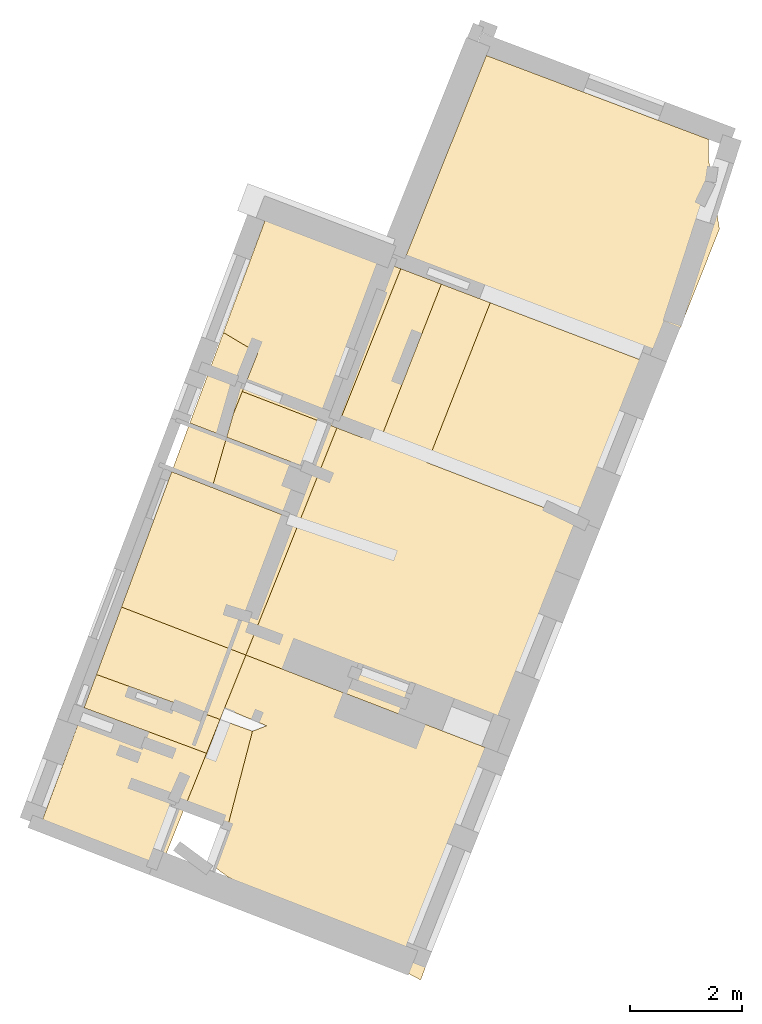
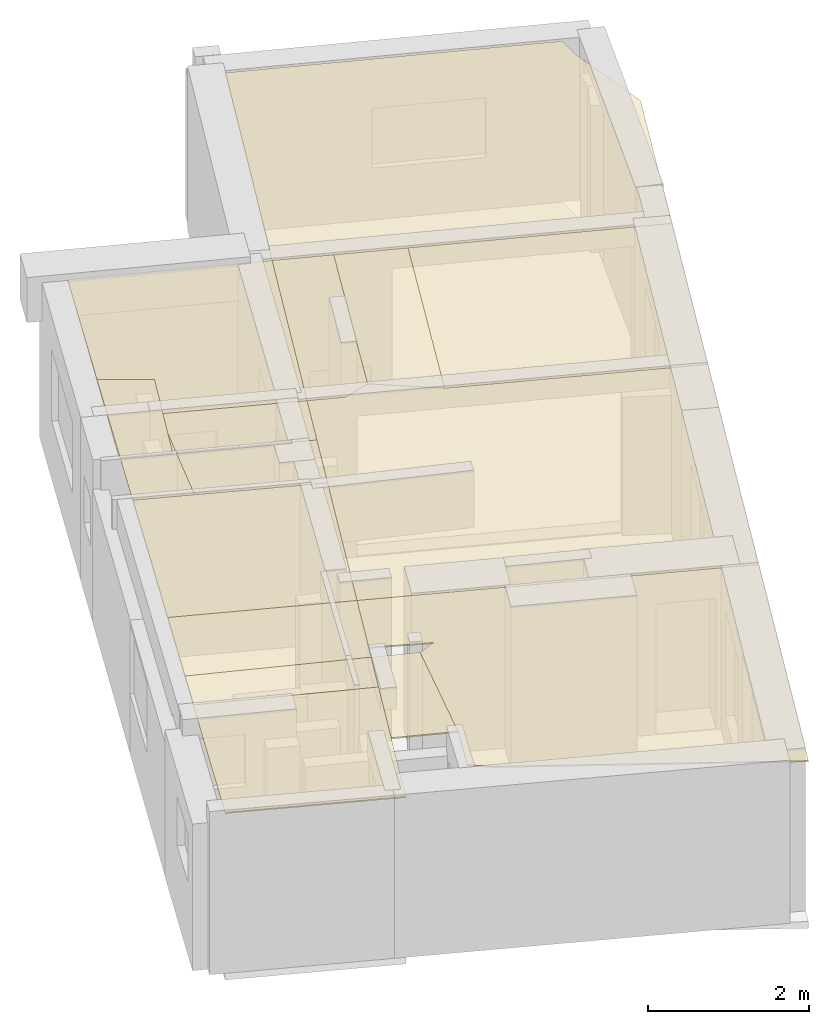
# One storey, part 4 of 5: 16 coverings.
"""IFC2X3 building model written with IfcOpenShell, lengths in metres."""

import ifcopenshell
import ifcopenshell.guid

model = None  # the IFC model being written
_history = None  # IfcOwnerHistory: only IFC2X3 demands one
_inside = {}  # id of a spatial element -> (the spatial element, [elements in it])
_under = {}  # id of a project, library or spatial element -> (it, [spatial elements below it])
_declared = {}  # id of a project -> (the project, [libraries it declares])
_typed = {}  # id of a type object -> (the type object, [elements of that type])
_made_of = {}  # id of a material, layer set ... -> (it, [elements and type objects made of it])


def new_model(schema):
    """Start an empty IFC model of exactly this schema.

    Asked for "IFC4X3", IfcOpenShell would pick the latest addendum, in which some entities
    have other attributes; the version numbers below select the first issue.
    IFC2X3 requires an IfcOwnerHistory on every rooted entity: one is made here for all.
    """
    global model, _history
    if schema == "IFC4X3":
        model = ifcopenshell.file(schema_version=(4, 3, 0, 0))
    else:
        model = ifcopenshell.file(schema=schema)
    _inside.clear()
    _under.clear()
    _declared.clear()
    _typed.clear()
    _made_of.clear()
    _history = None
    if model.schema == "IFC2X3":
        org = make("IfcOrganization", Name="unknown")
        user = make(
            "IfcPersonAndOrganization",
            ThePerson=make("IfcPerson", FamilyName="unknown"),
            TheOrganization=org,
        )
        app = make(
            "IfcApplication",
            ApplicationDeveloper=org,
            Version="unknown",
            ApplicationFullName="unknown",
            ApplicationIdentifier="unknown",
        )
        _history = make(
            "IfcOwnerHistory",
            OwningUser=user,
            OwningApplication=app,
            ChangeAction="ADDED",
            CreationDate=0,
        )
    return model


def make(cls, **values):
    """One entity of the class cls with the attributes given. An attribute that is None is left unset."""
    return model.create_entity(
        cls, **{name: value for name, value in values.items() if value is not None}
    )


def entity(cls, *values):
    """Any entity or typed value of the class cls, its attributes in the order of the schema. None: left unset."""
    e = model.create_entity(cls)
    for i, value in enumerate(values):
        if value is not None:
            e[i] = value
    return e


def rooted(cls, **values):
    """An entity with a GlobalId (a new one), such as an element, a storey or a relation."""
    return make(cls, GlobalId=ifcopenshell.guid.new(), OwnerHistory=_history, **values)


def si_unit(unit_type, name, prefix=None):
    """IfcSIUnit, for example si_unit("LENGTHUNIT", "METRE", prefix="MILLI")."""
    return make("IfcSIUnit", UnitType=unit_type, Prefix=prefix, Name=name)


def converted_unit(unit_type, name, factor, base, dimensions=None, offset=None):
    """IfcConversionBasedUnit, such as the inch: factor (a typed value) times the base unit."""
    return make(
        "IfcConversionBasedUnit"
        if offset is None
        else "IfcConversionBasedUnitWithOffset",
        ConversionOffset=offset,
        Dimensions=None
        if dimensions is None
        else entity("IfcDimensionalExponents", *dimensions),
        UnitType=unit_type,
        Name=name,
        ConversionFactor=make(
            "IfcMeasureWithUnit", ValueComponent=factor, UnitComponent=base
        ),
    )


def derived_unit(unit_type, elements):
    """IfcDerivedUnit: a product of units, each with its exponent."""
    return make(
        "IfcDerivedUnit",
        Elements=[
            make("IfcDerivedUnitElement", Unit=unit, Exponent=power)
            for unit, power in elements
        ],
        UnitType=unit_type,
    )


def assignment(units):
    """IfcUnitAssignment: the units of a project."""
    return None if units is None else make("IfcUnitAssignment", Units=units)


def point(xyz):
    """IfcCartesianPoint."""
    return None if xyz is None else make("IfcCartesianPoint", Coordinates=xyz)


def direction(xyz):
    """IfcDirection."""
    return None if xyz is None else make("IfcDirection", DirectionRatios=xyz)


def frame(location, z_axis=None, x_axis=None):
    """IfcAxis2Placement3D, a coordinate frame: its origin and axes. An axis left out is left unset."""
    return make(
        "IfcAxis2Placement3D",
        Location=point(location),
        Axis=direction(z_axis),
        RefDirection=direction(x_axis),
    )


def origin():
    """The frame at (0, 0, 0) with its axes left unset."""
    return frame((0.0, 0.0, 0.0))


def origin_with_axes():
    """The frame at (0, 0, 0) with the z axis (0, 0, 1) and the x axis (1, 0, 0) written out."""
    return frame((0.0, 0.0, 0.0), z_axis=(0.0, 0.0, 1.0), x_axis=(1.0, 0.0, 0.0))


def place(relative_to, where):
    """IfcLocalPlacement: puts the frame where relative to a parent placement (None: the world)."""
    return make(
        "IfcLocalPlacement", PlacementRelTo=relative_to, RelativePlacement=where
    )


def context(
    kind, dimensions, precision=None, world=None, true_north=None, identifier=None
):
    """IfcGeometricRepresentationContext, for example the 3D "Model" context."""
    return make(
        "IfcGeometricRepresentationContext",
        ContextIdentifier=identifier,
        ContextType=kind,
        CoordinateSpaceDimension=dimensions,
        Precision=precision,
        WorldCoordinateSystem=world,
        TrueNorth=true_north,
    )


def subcontext(parent, identifier, kind, view, scale=None):
    """IfcGeometricRepresentationSubContext, for example "Body" below "Model"."""
    return make(
        "IfcGeometricRepresentationSubContext",
        ContextIdentifier=identifier,
        ContextType=kind,
        ParentContext=parent,
        TargetScale=scale,
        TargetView=view,
    )


def project(units=None, contexts=None):
    """IfcProject with its units and contexts."""
    return rooted(
        "IfcProject",
        Name="project",
        RepresentationContexts=contexts,
        UnitsInContext=assignment(units),
    )


def spatial(cls, under=None, at=None, **own):
    """A site, building, storey or space (cls), placed at a placement, below another one or the project."""
    s = rooted(cls, ObjectPlacement=at, **own)
    if under is not None:
        _under.setdefault(under.id(), (under, []))[1].append(s)
    return s


def polyline(points):
    """IfcPolyline through the points."""
    return make("IfcPolyline", Points=[point(p) for p in points])


def outline(outer, holes=None, kind="AREA"):
    """IfcArbitraryClosedProfileDef: a profile drawn as a closed curve; with holes, ...WithVoids."""
    if holes is None:
        return make("IfcArbitraryClosedProfileDef", ProfileType=kind, OuterCurve=outer)
    return make(
        "IfcArbitraryProfileDefWithVoids",
        ProfileType=kind,
        OuterCurve=outer,
        InnerCurves=holes,
    )


def extrude(swept, where, along, depth):
    """IfcExtrudedAreaSolid: the profile swept, set in the frame where, extruded along a direction by depth."""
    return make(
        "IfcExtrudedAreaSolid",
        SweptArea=swept,
        Position=where,
        ExtrudedDirection=direction(along),
        Depth=depth,
    )


def shape(context_of_items, identifier, shape_type, items):
    """IfcShapeRepresentation: the items that make up one representation, for example the "Body"."""
    return make(
        "IfcShapeRepresentation",
        ContextOfItems=context_of_items,
        RepresentationIdentifier=identifier,
        RepresentationType=shape_type,
        Items=items,
    )


def material(Name=None, Category=None):
    """IfcMaterial."""
    return make("IfcMaterial", Name=Name, Category=Category)


def layer(
    of_material, thickness, ventilated=None, Name=None, Category=None, Priority=None
):
    """IfcMaterialLayer: one layer of a wall or slab, of a material (None: an air gap)."""
    return make(
        "IfcMaterialLayer",
        Material=of_material,
        LayerThickness=thickness,
        IsVentilated=ventilated,
        Name=Name,
        Category=Category,
        Priority=Priority,
    )


def layer_set(layers, Name=None):
    """IfcMaterialLayerSet."""
    return make("IfcMaterialLayerSet", MaterialLayers=layers, LayerSetName=Name)


def layer_usage(for_layer_set, set_direction, sense, offset, extent=None):
    """IfcMaterialLayerSetUsage: how a layer set lies in its element."""
    return make(
        "IfcMaterialLayerSetUsage",
        ForLayerSet=for_layer_set,
        LayerSetDirection=set_direction,
        DirectionSense=sense,
        OffsetFromReferenceLine=offset,
        ReferenceExtent=extent,
    )


def made_of(thing, what):
    """Note that an element or type object is made of a material, layer set ...; save() writes the relation."""
    if what is not None:
        _made_of.setdefault(what.id(), (what, []))[1].append(thing)
    return thing


def type_object(cls, material=None, **own):
    """A type object (cls), such as IfcWallType, which elements share."""
    return made_of(rooted(cls, **own), material)


def element(
    cls,
    number,
    at=None,
    inside=None,
    cuts=None,
    type_object=None,
    material=None,
    context=None,
    identifier="Body",
    shape_type=None,
    held_by="IfcProductDefinitionShape",
    body=None,
    shapes=None,
    **own,
):
    """One element of the class cls, such as IfcWall. Its Tag is "e" and its number.

    at: its placement. inside: the storey or other place that contains it. cuts: it is an
    opening in that element (IfcRelVoidsElement). A single representation is given by context,
    identifier, shape_type and body (its items); several are given by shapes. held_by: the class
    of the entity that holds the representations. save() writes the other relations.
    """
    e = rooted(cls, Tag="e%d" % number, ObjectPlacement=at, **own)
    if body is not None:
        shapes = [shape(context, identifier, shape_type, body)]
    if shapes is not None:
        e.Representation = make(held_by, Representations=shapes)
    if inside is not None:
        _inside.setdefault(inside.id(), (inside, []))[1].append(e)
    if cuts is not None:
        rooted(
            "IfcRelVoidsElement", RelatingBuildingElement=cuts, RelatedOpeningElement=e
        )
    if type_object is not None:
        _typed.setdefault(type_object.id(), (type_object, []))[1].append(e)
    return made_of(e, material)


def aggregate(whole, parts):
    """IfcRelAggregates: a whole, such as a stair, and the parts it consists of."""
    return rooted("IfcRelAggregates", RelatingObject=whole, RelatedObjects=parts)


def save(model, path):
    """Write the relations noted so far, then the file.

    IfcRelAggregates (storeys below a building ...), IfcRelContainedInSpatialStructure (elements
    in a storey), IfcRelDefinesByType, IfcRelAssociatesMaterial and IfcRelDeclares: one each for
    every whole, place, type object, material and project.
    """
    for whole, parts in _under.values():
        aggregate(whole, parts)
    for where, things in _inside.values():
        rooted(
            "IfcRelContainedInSpatialStructure",
            RelatedElements=things,
            RelatingStructure=where,
        )
    for kind, things in _typed.values():
        rooted("IfcRelDefinesByType", RelatedObjects=things, RelatingType=kind)
    for what, things in _made_of.values():
        rooted("IfcRelAssociatesMaterial", RelatedObjects=things, RelatingMaterial=what)
    for by, libraries in _declared.values():
        rooted("IfcRelDeclares", RelatingContext=by, RelatedDefinitions=libraries)
    model.write(path)


model = new_model("IFC2X3")

# Units and contexts
model_context = context("Model", 3, precision=1e-05, world=origin(), true_north=direction((0.0, 1.0)))
body_context = subcontext(model_context, "Body", "Model", "MODEL_VIEW")
ifc_project = project(units=[si_unit("LENGTHUNIT", "METRE"), si_unit("AREAUNIT", "SQUARE_METRE"), si_unit("VOLUMEUNIT", "CUBIC_METRE"), converted_unit("PLANEANGLEUNIT", "DEGREE", entity("IfcRatioMeasure", 0.0174532925199433), si_unit("PLANEANGLEUNIT", "RADIAN"), dimensions=[0, 0, 0, 0, 0, 0, 0]), si_unit("MASSUNIT", "GRAM", prefix="KILO"), derived_unit("MASSDENSITYUNIT", [(si_unit("MASSUNIT", "GRAM", prefix="KILO"), 1), (si_unit("LENGTHUNIT", "METRE"), -3)]), derived_unit("MOMENTOFINERTIAUNIT", [(si_unit("LENGTHUNIT", "METRE"), 4)]), si_unit("TIMEUNIT", "SECOND"), si_unit("FREQUENCYUNIT", "HERTZ"), si_unit("THERMODYNAMICTEMPERATUREUNIT", "DEGREE_CELSIUS"), derived_unit("THERMALTRANSMITTANCEUNIT", [(si_unit("MASSUNIT", "GRAM", prefix="KILO"), 1), (si_unit("THERMODYNAMICTEMPERATUREUNIT", "KELVIN"), -1), (si_unit("TIMEUNIT", "SECOND"), -3)]), derived_unit("VOLUMETRICFLOWRATEUNIT", [(si_unit("LENGTHUNIT", "METRE"), 3), (si_unit("TIMEUNIT", "SECOND"), -1)]), si_unit("ELECTRICCURRENTUNIT", "AMPERE"), si_unit("ELECTRICVOLTAGEUNIT", "VOLT"), si_unit("POWERUNIT", "WATT"), si_unit("FORCEUNIT", "NEWTON", prefix="KILO"), si_unit("ILLUMINANCEUNIT", "LUX"), si_unit("LUMINOUSFLUXUNIT", "LUMEN"), si_unit("LUMINOUSINTENSITYUNIT", "CANDELA"), derived_unit("USERDEFINED", [(si_unit("MASSUNIT", "GRAM", prefix="KILO"), -1), (si_unit("LENGTHUNIT", "METRE"), -2), (si_unit("TIMEUNIT", "SECOND"), 3), (si_unit("LUMINOUSFLUXUNIT", "LUMEN"), 1)]), derived_unit("LINEARVELOCITYUNIT", [(si_unit("LENGTHUNIT", "METRE"), 1), (si_unit("TIMEUNIT", "SECOND"), -1)]), si_unit("PRESSUREUNIT", "PASCAL"), derived_unit("USERDEFINED", [(si_unit("LENGTHUNIT", "METRE"), -2), (si_unit("MASSUNIT", "GRAM", prefix="KILO"), 1), (si_unit("TIMEUNIT", "SECOND"), -2)]), derived_unit("LINEARFORCEUNIT", [(si_unit("MASSUNIT", "GRAM", prefix="KILO"), 1), (si_unit("LENGTHUNIT", "METRE"), 1), (si_unit("TIMEUNIT", "SECOND"), -2), (si_unit("LENGTHUNIT", "METRE"), -1)]), derived_unit("PLANARFORCEUNIT", [(si_unit("MASSUNIT", "GRAM", prefix="KILO"), 1), (si_unit("LENGTHUNIT", "METRE"), 1), (si_unit("TIMEUNIT", "SECOND"), -2), (si_unit("LENGTHUNIT", "METRE"), -2)])], contexts=[model_context])

# Site, building, storey
placement = place(None, origin())
site = spatial("IfcSite", under=ifc_project, at=placement, CompositionType="ELEMENT")
building = spatial("IfcBuilding", under=site, at=placement, CompositionType="ELEMENT")
storey_placement = place(placement, frame((0.0, 0.0, -81.7791442871094)))
storey = spatial("IfcBuildingStorey", under=building, at=storey_placement, Name="Level 1", CompositionType="ELEMENT", Elevation=-81.7791442871094)

# Coverings
ifc_material = material(Name="Covering default")
ifc_layer_1 = layer(ifc_material, 0.02)
ifc_layer_set_1 = layer_set([ifc_layer_1], Name="Covering : 20mm")
ifc_layer_usage_1 = layer_usage(ifc_layer_set_1, "AXIS3", "POSITIVE", 0.0)
covering_type_1 = type_object("IfcCoveringType", Name="Covering : 20mm", PredefinedType="CEILING")
covering_1_placement = place(placement, frame((0.0, 0.0, -79.364875793457)))
element("IfcCovering", 1, at=covering_1_placement, inside=storey, type_object=covering_type_1, material=ifc_layer_usage_1, Name="Covering : 20mm", ObjectType="Covering : 20mm", PredefinedType="CEILING", context=body_context, shape_type="SweptSolid", body=[
    extrude(outline(polyline([(-6.27504014968872, 2.44042992591858), (-4.0716700553894, 1.63903999328613), (-4.31356000900269, 1.03594994544983), (-6.49514007568359, 1.84764003753662), (-6.27504014968872, 2.44042992591858)])), origin_with_axes(), (0.0, 0.0, 1.0), 0.02),
])
ifc_layer_2 = layer(ifc_material, 0.02)
ifc_layer_set_2 = layer_set([ifc_layer_2], Name="Covering : 20mm")
ifc_layer_usage_2 = layer_usage(ifc_layer_set_2, "AXIS3", "POSITIVE", 0.0)
covering_type_2 = type_object("IfcCoveringType", Name="Covering : 20mm", PredefinedType="CEILING")
covering_2_placement = place(placement, frame((0.0, 0.0, -79.364875793457)))
element("IfcCovering", 2, at=covering_2_placement, inside=storey, type_object=covering_type_2, material=ifc_layer_usage_2, Name="Covering : 20mm", ObjectType="Covering : 20mm", PredefinedType="CEILING", context=body_context, shape_type="SweptSolid", body=[
    extrude(outline(polyline([(-6.27504014968872, 2.44042992591858), (-5.82860994338989, 3.64277005195618), (-3.6112699508667, 2.78693008422852), (-3.99167990684509, 1.83849000930786), (-4.0716700553894, 1.63903999328613), (-6.27504014968872, 2.44042992591858)])), origin_with_axes(), (0.0, 0.0, 1.0), 0.02),
])
ifc_layer_3 = layer(ifc_material, 0.02)
ifc_layer_set_3 = layer_set([ifc_layer_3], Name="Covering : 20mm")
ifc_layer_usage_3 = layer_usage(ifc_layer_set_3, "AXIS3", "POSITIVE", 0.0)
covering_type_3 = type_object("IfcCoveringType", Name="Covering : 20mm", PredefinedType="CEILING")
covering_3_placement = place(placement, frame((0.0, 0.0, -79.364875793457)))
element("IfcCovering", 3, at=covering_3_placement, inside=storey, type_object=covering_type_3, material=ifc_layer_usage_3, Name="Covering : 20mm", ObjectType="Covering : 20mm", PredefinedType="CEILING", context=body_context, shape_type="SweptSolid", body=[
    extrude(outline(polyline([(-1.15748000144958, 6.77277994155884), (-0.127580001950264, 9.39822006225586), (0.744549989700317, 9.06659984588623), (-0.377480000257492, 6.21557998657227), (-1.15748000144958, 6.77277994155884)])), origin_with_axes(), (0.0, 0.0, 1.0), 0.02),
])
ifc_layer_4 = layer(ifc_material, 0.02)
ifc_layer_set_4 = layer_set([ifc_layer_4], Name="Covering : 20mm")
ifc_layer_usage_4 = layer_usage(ifc_layer_set_4, "AXIS3", "POSITIVE", 0.0)
covering_type_4 = type_object("IfcCoveringType", Name="Covering : 20mm", PredefinedType="CEILING")
covering_4_placement = place(placement, frame((0.0, 0.0, -79.364875793457)))
element("IfcCovering", 4, at=covering_4_placement, inside=storey, type_object=covering_type_4, material=ifc_layer_usage_4, Name="Covering : 20mm", ObjectType="Covering : 20mm", PredefinedType="CEILING", context=body_context, shape_type="SweptSolid", body=[
    extrude(outline(polyline([(-3.83523011207581, 7.08568000793457), (-3.71643996238708, 7.50004005432129), (-4.31142997741699, 7.72891998291016), (-4.61093997955322, 6.92226982116699), (-4.93342018127441, 6.05374002456665), (-4.21158981323242, 5.77279996871948), (-3.95431995391846, 6.67025995254517), (-3.83523011207581, 7.08568000793457)])), origin_with_axes(), (0.0, 0.0, 1.0), 0.02),
])
ifc_layer_5 = layer(ifc_material, 0.02)
ifc_layer_set_5 = layer_set([ifc_layer_5], Name="Covering : 20mm")
ifc_layer_usage_5 = layer_usage(ifc_layer_set_5, "AXIS3", "POSITIVE", 0.0)
covering_type_5 = type_object("IfcCoveringType", Name="Covering : 20mm", PredefinedType="CEILING")
covering_5_placement = place(placement, frame((0.0, 0.0, -79.364875793457)))
element("IfcCovering", 5, at=covering_5_placement, inside=storey, type_object=covering_type_5, material=ifc_layer_usage_5, Name="Covering : 20mm", ObjectType="Covering : 20mm", PredefinedType="CEILING", context=body_context, shape_type="SweptSolid", body=[
    extrude(outline(polyline([(-3.83523011207581, 7.08568000793457), (-3.95431995391846, 6.67025995254517), (-2.30727005004883, 6.0381498336792), (-1.98766994476318, 6.83500003814697), (-3.67479991912842, 7.4840202331543), (-3.83523011207581, 7.08568000793457)])), origin_with_axes(), (0.0, 0.0, 1.0), 0.02),
])
ifc_layer_6 = layer(ifc_material, 0.02)
ifc_layer_set_6 = layer_set([ifc_layer_6], Name="Covering : 20mm")
ifc_layer_usage_6 = layer_usage(ifc_layer_set_6, "AXIS3", "POSITIVE", 0.0)
covering_type_6 = type_object("IfcCoveringType", Name="Covering : 20mm", PredefinedType="CEILING")
covering_6_placement = place(placement, frame((0.0, 0.0, -79.364875793457)))
element("IfcCovering", 6, at=covering_6_placement, inside=storey, type_object=covering_type_6, material=ifc_layer_usage_6, Name="Covering : 20mm", ObjectType="Covering : 20mm", PredefinedType="CEILING", context=body_context, shape_type="SweptSolid", body=[
    extrude(outline(polyline([(-3.49388003349304, 1.42888998985291), (-4.0716700553894, 1.63903999328613), (-4.31356000900269, 1.03594994544983), (-4.7262601852417, 0.00698000006377697), (-3.94035005569458, -0.28753998875618), (-3.49388003349304, 1.42888998985291)])), origin_with_axes(), (0.0, 0.0, 1.0), 0.02),
])
ifc_layer_7 = layer(ifc_material, 0.02)
ifc_layer_set_7 = layer_set([ifc_layer_7], Name="Covering : 20mm")
ifc_layer_usage_7 = layer_usage(ifc_layer_set_7, "AXIS3", "POSITIVE", 0.0)
covering_type_7 = type_object("IfcCoveringType", Name="Covering : 20mm", PredefinedType="CEILING")
covering_7_placement = place(placement, frame((0.0, 0.0, -79.364875793457)))
element("IfcCovering", 7, at=covering_7_placement, inside=storey, type_object=covering_type_7, material=ifc_layer_usage_7, Name="Covering : 20mm", ObjectType="Covering : 20mm", PredefinedType="CEILING", context=body_context, shape_type="SweptSolid", body=[
    extrude(outline(polyline([(-3.50592994689941, 8.23437023162842), (-4.01208019256592, 8.53514003753662), (-4.31142997741699, 7.72891998291016), (-4.61093997955322, 6.92226982116699), (-3.99607992172241, 6.68628978729248), (-3.83523011207581, 7.08568000793457), (-3.67479991912842, 7.4840202331543), (-3.39833998680115, 8.17043972015381), (-3.50592994689941, 8.23437023162842)])), origin_with_axes(), (0.0, 0.0, 1.0), 0.02),
])
ifc_layer_8 = layer(ifc_material, 0.02)
ifc_layer_set_8 = layer_set([ifc_layer_8], Name="Covering : 20mm")
ifc_layer_usage_8 = layer_usage(ifc_layer_set_8, "AXIS3", "POSITIVE", 0.0)
covering_type_8 = type_object("IfcCoveringType", Name="Covering : 20mm", PredefinedType="CEILING")
covering_8_placement = place(placement, frame((0.0, 0.0, -79.364875793457)))
element("IfcCovering", 8, at=covering_8_placement, inside=storey, type_object=covering_type_8, material=ifc_layer_usage_8, Name="Covering : 20mm", ObjectType="Covering : 20mm", PredefinedType="CEILING", context=body_context, shape_type="SweptSolid", body=[
    extrude(outline(polyline([(-3.50592994689941, 8.23437023162842), (-4.01208019256592, 8.53514003753662), (-3.2506799697876, 10.5857696533203), (-0.849510014057159, 9.67273044586182), (-1.98766994476318, 6.83500003814697), (-3.67479991912842, 7.4840202331543), (-3.39833998680115, 8.17043972015381), (-3.50592994689941, 8.23437023162842)])), origin_with_axes(), (0.0, 0.0, 1.0), 0.02),
])
ifc_layer_9 = layer(ifc_material, 0.02)
ifc_layer_set_9 = layer_set([ifc_layer_9], Name="Covering : 20mm")
ifc_layer_usage_9 = layer_usage(ifc_layer_set_9, "AXIS3", "POSITIVE", 0.0)
covering_type_9 = type_object("IfcCoveringType", Name="Covering : 20mm", PredefinedType="CEILING")
covering_9_placement = place(placement, frame((0.0, 0.0, -79.364875793457)))
element("IfcCovering", 9, at=covering_9_placement, inside=storey, type_object=covering_type_9, material=ifc_layer_usage_9, Name="Covering : 20mm", ObjectType="Covering : 20mm", PredefinedType="CEILING", context=body_context, shape_type="SweptSolid", body=[
    extrude(outline(polyline([(-1.15748000144958, 6.77277994155884), (-0.127580001950264, 9.39822006225586), (-0.849510014057159, 9.67273044586182), (-1.98766994476318, 6.83500003814697), (-1.53718996047974, 6.66170978546143), (-1.15748000144958, 6.77277994155884)])), origin_with_axes(), (0.0, 0.0, 1.0), 0.02),
])
ifc_layer_10 = layer(ifc_material, 0.02)
ifc_layer_set_10 = layer_set([ifc_layer_10], Name="Covering : 20mm")
ifc_layer_usage_10 = layer_usage(ifc_layer_set_10, "AXIS3", "POSITIVE", 0.0)
covering_type_10 = type_object("IfcCoveringType", Name="Covering : 20mm", PredefinedType="CEILING")
covering_10_placement = place(placement, frame((0.0, 0.0, -79.364875793457)))
element("IfcCovering", 10, at=covering_10_placement, inside=storey, type_object=covering_type_10, material=ifc_layer_usage_10, Name="Covering : 20mm", ObjectType="Covering : 20mm", PredefinedType="CEILING", context=body_context, shape_type="SweptSolid", body=[
    extrude(outline(polyline([(-4.31356000900269, 1.03594994544983), (-6.49514007568359, 1.84764003753662), (-7.31494998931885, -0.360320001840591), (-5.2023401260376, -1.17999005317688), (-4.90777015686035, -0.44556999206543), (-4.7262601852417, 0.00698000006377697), (-4.31356000900269, 1.03594994544983)])), origin_with_axes(), (0.0, 0.0, 1.0), 0.02),
])
ifc_layer_11 = layer(ifc_material, 0.02)
ifc_layer_set_11 = layer_set([ifc_layer_11], Name="Covering : 20mm")
ifc_layer_usage_11 = layer_usage(ifc_layer_set_11, "AXIS3", "POSITIVE", 0.0)
covering_type_11 = type_object("IfcCoveringType", Name="Covering : 20mm", PredefinedType="CEILING")
covering_11_placement = place(placement, frame((0.0, 0.0, -79.364875793457)))
element("IfcCovering", 11, at=covering_11_placement, inside=storey, type_object=covering_type_11, material=ifc_layer_usage_11, Name="Covering : 20mm", ObjectType="Covering : 20mm", PredefinedType="CEILING", context=body_context, shape_type="SweptSolid", body=[
    extrude(outline(polyline([(-4.93342018127441, 6.05374002456665), (-5.82860994338989, 3.64277005195618), (-3.6112699508667, 2.78693008422852), (-2.65646004676819, 5.16752004623413), (-4.21158981323242, 5.77279996871948), (-4.93342018127441, 6.05374002456665)])), origin_with_axes(), (0.0, 0.0, 1.0), 0.02),
])
ifc_layer_12 = layer(ifc_material, 0.02)
ifc_layer_set_12 = layer_set([ifc_layer_12], Name="Covering : 20mm")
ifc_layer_usage_12 = layer_usage(ifc_layer_set_12, "AXIS3", "POSITIVE", 0.0)
covering_type_12 = type_object("IfcCoveringType", Name="Covering : 20mm", PredefinedType="CEILING")
covering_12_placement = place(placement, frame((0.0, 0.0, -79.364875793457)))
element("IfcCovering", 12, at=covering_12_placement, inside=storey, type_object=covering_type_12, material=ifc_layer_usage_12, Name="Covering : 20mm", ObjectType="Covering : 20mm", PredefinedType="CEILING", context=body_context, shape_type="SweptSolid", body=[
    extrude(outline(polyline([(-4.21158981323242, 5.77279996871948), (-3.95431995391846, 6.67025995254517), (-2.30727005004883, 6.0381498336792), (-2.65646004676819, 5.16752004623413), (-4.21158981323242, 5.77279996871948)])), origin_with_axes(), (0.0, 0.0, 1.0), 0.02),
])
ifc_layer_13 = layer(ifc_material, 0.02)
ifc_layer_set_13 = layer_set([ifc_layer_13], Name="Covering : 20mm")
ifc_layer_usage_13 = layer_usage(ifc_layer_set_13, "AXIS3", "POSITIVE", 0.0)
covering_type_13 = type_object("IfcCoveringType", Name="Covering : 20mm", PredefinedType="CEILING")
covering_13_placement = place(placement, frame((0.0, 0.0, -79.364875793457)))
element("IfcCovering", 13, at=covering_13_placement, inside=storey, type_object=covering_type_13, material=ifc_layer_usage_13, Name="Covering : 20mm", ObjectType="Covering : 20mm", PredefinedType="CEILING", context=body_context, shape_type="SweptSolid", body=[
    extrude(outline(polyline([(3.83908009529114, 7.88992023468018), (2.70121002197266, 5.03125), (-0.377480000257492, 6.21557998657227), (0.744549989700317, 9.06659984588623), (3.83908009529114, 7.88992023468018)])), origin_with_axes(), (0.0, 0.0, 1.0), 0.02),
])
ifc_layer_14 = layer(ifc_material, 0.02)
ifc_layer_set_14 = layer_set([ifc_layer_14], Name="Covering : 20mm")
ifc_layer_usage_14 = layer_usage(ifc_layer_set_14, "AXIS3", "POSITIVE", 0.0)
covering_type_14 = type_object("IfcCoveringType", Name="Covering : 20mm", PredefinedType="CEILING")
covering_14_placement = place(placement, frame((0.0, 0.0, -79.364875793457)))
element("IfcCovering", 14, at=covering_14_placement, inside=storey, type_object=covering_type_14, material=ifc_layer_usage_14, Name="Covering : 20mm", ObjectType="Covering : 20mm", PredefinedType="CEILING", context=body_context, shape_type="SweptSolid", body=[
    extrude(outline(polyline([(0.744549989700317, 9.06659984588623), (3.83908009529114, 7.88992023468018), (4.83017015457153, 10.3798503875732), (4.63234996795654, 11.6451902389526), (4.63234996795654, 11.9805402755737), (0.67492002248764, 13.4735298156738), (-0.849510014057159, 9.67273044586182), (-0.127580001950264, 9.39822006225586), (0.744549989700317, 9.06659984588623)])), origin_with_axes(), (0.0, 0.0, 1.0), 0.02),
])
ifc_layer_15 = layer(ifc_material, 0.02)
ifc_layer_set_15 = layer_set([ifc_layer_15], Name="Covering : 20mm")
ifc_layer_usage_15 = layer_usage(ifc_layer_set_15, "AXIS3", "POSITIVE", 0.0)
covering_type_15 = type_object("IfcCoveringType", Name="Covering : 20mm", PredefinedType="CEILING")
covering_15_placement = place(placement, frame((0.0, 0.0, -79.364875793457)))
element("IfcCovering", 15, at=covering_15_placement, inside=storey, type_object=covering_type_15, material=ifc_layer_usage_15, Name="Covering : 20mm", ObjectType="Covering : 20mm", PredefinedType="CEILING", context=body_context, shape_type="SweptSolid", body=[
    extrude(outline(polyline([(-0.497680008411407, -3.00534009933472), (1.08619999885559, 0.973829984664917), (-3.6112699508667, 2.78693008422852), (-3.99167990684509, 1.83849000930786), (-3.24238991737366, 1.52546000480652), (-3.49388003349304, 1.42888998985291), (-3.94035005569458, -0.28753998875618), (-4.20233011245728, -0.968050003051758), (-3.93070006370544, -1.16923999786377), (-0.497680008411407, -3.00534009933472)])), origin_with_axes(), (0.0, 0.0, 1.0), 0.02),
])
ifc_layer_16 = layer(ifc_material, 0.02)
ifc_layer_set_16 = layer_set([ifc_layer_16], Name="Covering : 20mm")
ifc_layer_usage_16 = layer_usage(ifc_layer_set_16, "AXIS3", "POSITIVE", 0.0)
covering_type_16 = type_object("IfcCoveringType", Name="Covering : 20mm", PredefinedType="CEILING")
covering_16_placement = place(placement, frame((0.0, 0.0, -79.364875793457)))
element("IfcCovering", 16, at=covering_16_placement, inside=storey, type_object=covering_type_16, material=ifc_layer_usage_16, Name="Covering : 20mm", ObjectType="Covering : 20mm", PredefinedType="CEILING", context=body_context, shape_type="SweptSolid", body=[
    extrude(outline(polyline([(2.70121002197266, 5.03125), (1.08619999885559, 0.973829984664917), (-3.6112699508667, 2.78693008422852), (-2.65646004676819, 5.16752004623413), (-2.30727005004883, 6.0381498336792), (-1.98766994476318, 6.83500003814697), (-1.53718996047974, 6.66170978546143), (-1.15748000144958, 6.77277994155884), (-0.377480000257492, 6.21557998657227), (2.70121002197266, 5.03125)])), origin_with_axes(), (0.0, 0.0, 1.0), 0.02),
])

save(model, "model.ifc")
